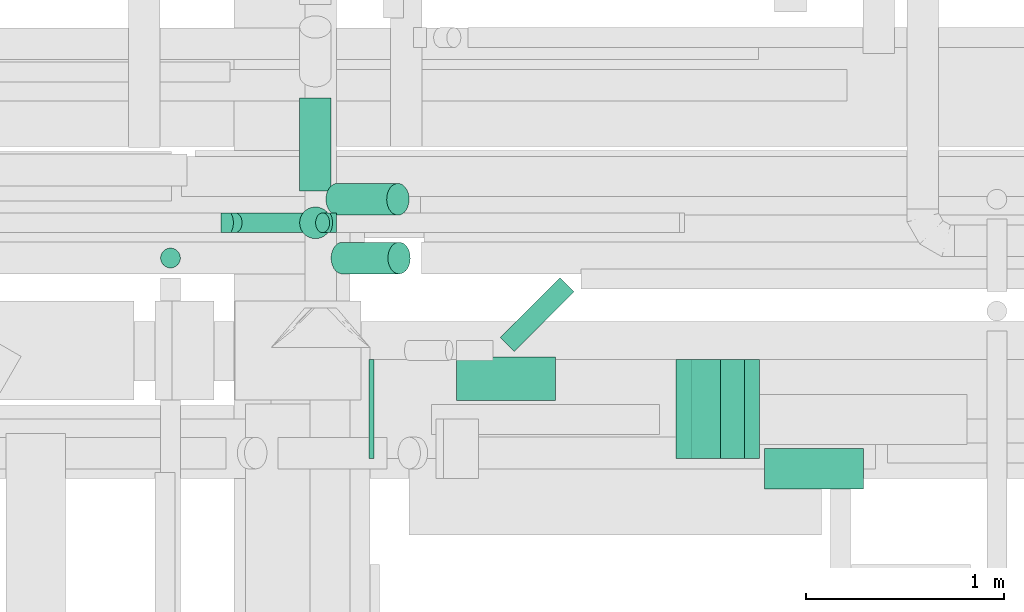
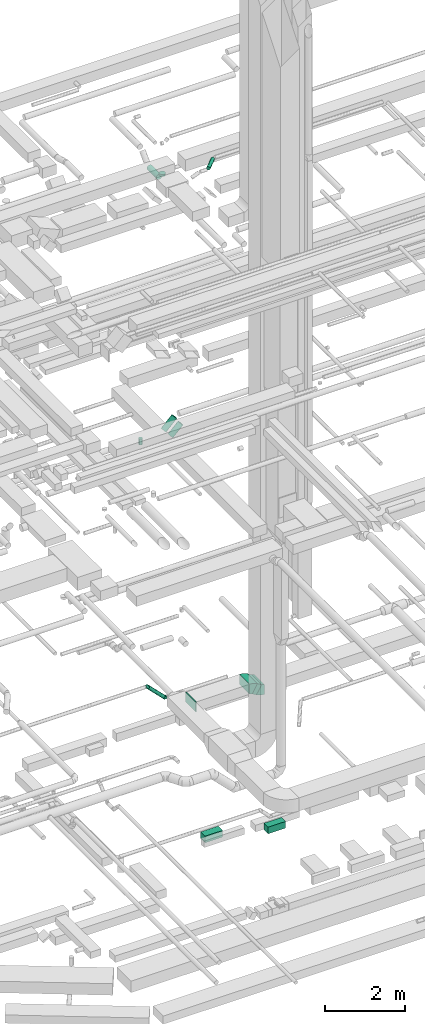
# One storey, part 135 of 337: 10 flow segments, 5 flow fittings.
"""IFC2X3 building model written with IfcOpenShell, lengths in millimetres."""

from ifc_helpers import new_model, entity, si_unit, converted_unit, derived_unit, direction, frame, frame_2d, origin, origin_2d_with_axis, place, context, subcontext, project, spatial, polyline, circle_curve, parameter, trimmed, segment, composite_curve, rectangle, circle, outline, extrude, faceted_brep, source, transform, mapped, material, type_object, type_shapes, element, save


model = new_model("IFC2X3")

# Units and contexts
model_context = context("Model", 3, precision=0.01, world=origin(), true_north=direction((6.12303176911189e-17, 1.0)))
body_context = subcontext(model_context, "Body", "Model", "MODEL_VIEW")
ifc_project = project(units=[si_unit("LENGTHUNIT", "METRE", prefix="MILLI"), si_unit("AREAUNIT", "SQUARE_METRE"), si_unit("VOLUMEUNIT", "CUBIC_METRE"), converted_unit("PLANEANGLEUNIT", "DEGREE", entity("IfcRatioMeasure", 0.0174532925199433), si_unit("PLANEANGLEUNIT", "RADIAN"), dimensions=[0, 0, 0, 0, 0, 0, 0]), si_unit("MASSUNIT", "GRAM", prefix="KILO"), derived_unit("MASSDENSITYUNIT", [(si_unit("MASSUNIT", "GRAM", prefix="KILO"), 1), (si_unit("LENGTHUNIT", "METRE"), -3)]), derived_unit("MOMENTOFINERTIAUNIT", [(si_unit("LENGTHUNIT", "METRE"), 4)]), si_unit("TIMEUNIT", "SECOND"), si_unit("FREQUENCYUNIT", "HERTZ"), si_unit("THERMODYNAMICTEMPERATUREUNIT", "DEGREE_CELSIUS"), derived_unit("THERMALTRANSMITTANCEUNIT", [(si_unit("MASSUNIT", "GRAM", prefix="KILO"), 1), (si_unit("THERMODYNAMICTEMPERATUREUNIT", "KELVIN"), -1), (si_unit("TIMEUNIT", "SECOND"), -3)]), derived_unit("VOLUMETRICFLOWRATEUNIT", [(si_unit("LENGTHUNIT", "METRE"), 3), (si_unit("TIMEUNIT", "SECOND"), -1)]), derived_unit("MASSFLOWRATEUNIT", [(si_unit("MASSUNIT", "GRAM", prefix="KILO"), 1), (si_unit("TIMEUNIT", "SECOND"), -1)]), derived_unit("ROTATIONALFREQUENCYUNIT", [(si_unit("TIMEUNIT", "SECOND"), -1)]), si_unit("ELECTRICCURRENTUNIT", "AMPERE"), si_unit("ELECTRICVOLTAGEUNIT", "VOLT"), si_unit("POWERUNIT", "WATT"), si_unit("FORCEUNIT", "NEWTON", prefix="KILO"), si_unit("ILLUMINANCEUNIT", "LUX"), si_unit("LUMINOUSFLUXUNIT", "LUMEN"), si_unit("LUMINOUSINTENSITYUNIT", "CANDELA"), derived_unit("USERDEFINED", [(si_unit("MASSUNIT", "GRAM", prefix="KILO"), -1), (si_unit("LENGTHUNIT", "METRE"), -2), (si_unit("TIMEUNIT", "SECOND"), 3), (si_unit("LUMINOUSFLUXUNIT", "LUMEN"), 1)]), derived_unit("LINEARVELOCITYUNIT", [(si_unit("LENGTHUNIT", "METRE"), 1), (si_unit("TIMEUNIT", "SECOND"), -1)]), si_unit("PRESSUREUNIT", "PASCAL"), derived_unit("USERDEFINED", [(si_unit("LENGTHUNIT", "METRE"), -2), (si_unit("MASSUNIT", "GRAM", prefix="KILO"), 1), (si_unit("TIMEUNIT", "SECOND"), -2)]), derived_unit("LINEARFORCEUNIT", [(si_unit("MASSUNIT", "GRAM", prefix="KILO"), 1), (si_unit("LENGTHUNIT", "METRE"), 1), (si_unit("TIMEUNIT", "SECOND"), -2), (si_unit("LENGTHUNIT", "METRE"), -1)]), derived_unit("PLANARFORCEUNIT", [(si_unit("MASSUNIT", "GRAM", prefix="KILO"), 1), (si_unit("LENGTHUNIT", "METRE"), 1), (si_unit("TIMEUNIT", "SECOND"), -2), (si_unit("LENGTHUNIT", "METRE"), -2)])], contexts=[model_context])

# Site, building, storey
site_placement = place(None, origin())
site = spatial("IfcSite", under=ifc_project, at=site_placement, CompositionType="ELEMENT")
building_placement = place(site_placement, origin())
building = spatial("IfcBuilding", under=site, at=building_placement, CompositionType="ELEMENT")
storey_placement = place(building_placement, origin())
storey = spatial("IfcBuildingStorey", under=building, at=storey_placement, CompositionType="ELEMENT", Elevation=0.0)

# Flow segments
duct_segment_type_1 = type_object("IfcDuctSegmentType", PredefinedType="NOTDEFINED")
flow_segment_1_placement = place(storey_placement, frame((24000.25, 14418.99, -1000.0)))
element("IfcFlowSegment", 1, at=flow_segment_1_placement, inside=storey, type_object=duct_segment_type_1, context=body_context, shape_type="SweptSolid", body=[
    extrude(rectangle(XDim=220.0, YDim=499.999999999999, at=origin_2d_with_axis()), frame((250.0, 110.0, 0.0), z_axis=(0.0, 0.0, 1.0), x_axis=(0.0, 1.0, 0.0)), (0.0, 0.0, 1.0), 200.0),
])
flow_segment_2_placement = place(storey_placement, frame((25553.23, 13973.99, -1000.0)))
element("IfcFlowSegment", 2, at=flow_segment_2_placement, inside=storey, type_object=duct_segment_type_1, context=body_context, shape_type="SweptSolid", body=[
    extrude(rectangle(XDim=204.999986748984, YDim=499.999999999999, at=origin_2d_with_axis()), frame((250.0, 102.5, 0.0), z_axis=(0.0, 0.0, 1.0), x_axis=(0.0, -1.0, 0.0)), (0.0, 0.0, 1.0), 200.0),
])
flow_segment_3_placement = place(storey_placement, frame((25183.09, 14126.58, 3210.29)))
element("IfcFlowSegment", 3, at=flow_segment_3_placement, inside=storey, type_object=duct_segment_type_1, context=body_context, shape_type="SweptSolid", body=[
    extrude(rectangle(XDim=300.0, YDim=139.230496196752, at=frame_2d((0.0, 0.0), x_axis=(0.0, 1.0))), frame((135.29, 0.0, 164.71), z_axis=(0.0, 1.0, 0.0), x_axis=(-0.866025410712616, 0.0, 0.499999988000045)), (0.0, 0.0, 1.0), 499.999999999999),
])
duct_segment_type_2 = type_object("IfcDuctSegmentType", PredefinedType="NOTDEFINED")
flow_segment_4_placement = place(storey_placement, frame((23366.75, 15056.69, 11058.7)))
element("IfcFlowSegment", 4, at=flow_segment_4_placement, inside=storey, type_object=duct_segment_type_2, context=body_context, shape_type="SweptSolid", body=[
    extrude(circle(Radius=80.0, at=origin_2d_with_axis()), frame((58.16, 81.6, 58.16), z_axis=(0.707106781186548, 0.0, 0.707106781186548), x_axis=(0.0, -1.0, 0.0)), (0.0, 0.0, 1.0), 404.852813742363),
])
flow_segment_5_placement = place(storey_placement, frame((23340.75, 15353.25, 11058.7)))
element("IfcFlowSegment", 5, at=flow_segment_5_placement, inside=storey, type_object=duct_segment_type_2, context=body_context, shape_type="SweptSolid", body=[
    extrude(circle(Radius=80.0, at=origin_2d_with_axis()), frame((58.16, 81.6, 58.16), z_axis=(0.707106781186548, 0.0, 0.707106781186548), x_axis=(0.0, -1.0, 0.0)), (0.0, 0.0, 1.0), 433.137084989856),
])
flow_segment_6_placement = place(storey_placement, frame((22847.03, 15264.53, 3092.34)))
element("IfcFlowSegment", 6, at=flow_segment_6_placement, inside=storey, type_object=duct_segment_type_2, context=body_context, shape_type="SweptSolid", body=[
    extrude(circle(Radius=50.0, at=origin_2d_with_axis()), frame((36.95, 51.6, 478.37), z_axis=(0.707106781186545, 0.0, -0.70710678118655), x_axis=(0.0, 1.0, 0.0)), (0.0, 0.0, 1.0), 624.264068711905),
])
flow_segment_7_placement = place(storey_placement, frame((22506.56, 15086.69, 11170.0)))
element("IfcFlowSegment", 7, at=flow_segment_7_placement, inside=storey, type_object=duct_segment_type_2, context=body_context, shape_type="SweptSolid", body=[
    extrude(circle(Radius=50.0, at=origin_2d_with_axis()), frame((51.6, 51.6, 0.0), z_axis=(0.0, 0.0, 1.0), x_axis=(-1.0, 0.0, 0.0)), (0.0, 0.0, 1.0), 179.999999999998),
])
flow_segment_8_placement = place(storey_placement, frame((24219.86, 14665.24, 19148.91)))
element("IfcFlowSegment", 8, at=flow_segment_8_placement, inside=storey, type_object=duct_segment_type_2, context=body_context, shape_type="SweptSolid", body=[
    extrude(circle(Radius=50.0, at=origin_2d_with_axis()), frame((36.95, 36.95, 51.6), z_axis=(0.707106781186558, 0.707106781186537, 0.0), x_axis=(-0.707106781186537, 0.707106781186558, 0.0)), (0.0, 0.0, 1.0), 426.274169979706),
])
flow_segment_9_placement = place(storey_placement, frame((23207.77, 15476.15, 18728.99)))
element("IfcFlowSegment", 9, at=flow_segment_9_placement, inside=storey, type_object=duct_segment_type_2, context=body_context, shape_type="SweptSolid", body=[
    extrude(circle(Radius=80.0, at=origin_2d_with_axis()), frame((81.6, 0.0, 81.6), z_axis=(0.0, 1.0, 0.0), x_axis=(-1.0, 0.0, 0.0)), (0.0, 0.0, 1.0), 468.725830020335),
])
flow_segment_10_placement = place(storey_placement, frame((23207.77, 15234.56, 18970.59)))
element("IfcFlowSegment", 10, at=flow_segment_10_placement, inside=storey, type_object=duct_segment_type_2, context=body_context, shape_type="SweptSolid", body=[
    extrude(circle(Radius=80.0, at=origin_2d_with_axis()), frame((81.6, 81.6, 0.0), z_axis=(0.0, 0.0, 1.0), x_axis=(-1.0, 0.0, 0.0)), (0.0, 0.0, 1.0), 59.4112549694471),
])

# Flow fittings
ifc_material = material()
duct_fitting_type_1 = type_object("IfcDuctFittingType", PredefinedType="NOTDEFINED", material=ifc_material)
shared_shape_1 = source(origin(), body_context, "Body", "SweptSolid", [
    extrude(rectangle(XDim=26.0960000000224, YDim=500.0, at=origin_2d_with_axis()), frame((6.95, 0.0, -150.0)), (0.0, 0.0, 1.0), 300.0),
])
type_shapes(duct_fitting_type_1, [shared_shape_1])
flow_fitting_placement = place(storey_placement, frame((23565.55, 14376.58, 3450.0), z_axis=(0.0, 0.0, -1.0), x_axis=(1.0, 0.0, 0.0)))
element("IfcFlowFitting", 11, at=flow_fitting_placement, inside=storey, type_object=duct_fitting_type_1, material=ifc_material, context=body_context, shape_type="MappedRepresentation", body=[
    mapped(shared_shape_1, transform((0.0, 0.0, 0.0), scale=1.0)),
])
duct_fitting_type_2 = type_object("IfcDuctFittingType", PredefinedType="NOTDEFINED", material=ifc_material)
shared_shape_2 = source(origin(), body_context, "Body", "Brep", [
    faceted_brep([(-41.42, 0.0, -50.0), (-41.42, -12.94, -48.3), (-41.42, -25.0, -43.3), (-41.42, -35.36, -35.36), (-41.42, -43.3, -25.0), (-41.42, -48.3, -12.94), (-41.42, -50.0, 0.0), (-41.42, -48.3, 12.94), (-41.42, -43.3, 25.0), (-41.42, -35.36, 35.36), (-41.42, -25.0, 43.3), (-41.42, -12.94, 48.3), (-41.42, 0.0, 50.0), (-41.42, 12.94, 48.3), (-41.42, 25.0, 43.3), (-41.42, 35.36, 35.36), (-41.42, 43.3, 25.0), (-41.42, 48.3, 12.94), (-41.42, 50.0, 0.0), (-41.42, 48.3, -12.94), (-41.42, 43.3, -25.0), (-41.42, 35.36, -35.36), (-41.42, 25.0, -43.3), (-41.42, 12.94, -48.3), (-5.36, 12.94, 48.3), (-10.36, 25.0, 43.3), (0.0, 0.0, 50.0), (-14.64, 35.36, 35.36), (-20.0, 48.3, 12.94), (-20.71, 50.0, 0.0), (-17.94, 43.3, 25.0), (-17.94, 43.3, -25.0), (-14.64, 35.36, -35.36), (-20.0, 48.3, -12.94), (-5.36, 12.94, -48.3), (0.0, 0.0, -50.0), (-10.36, 25.0, -43.3), (5.36, -12.94, -48.3), (10.36, -25.0, -43.3), (14.64, -35.36, -35.36), (17.94, -43.3, -25.0), (20.0, -48.3, -12.94), (20.71, -50.0, 0.0), (20.0, -48.3, 12.94), (17.94, -43.3, 25.0), (14.64, -35.36, 35.36), (10.36, -25.0, 43.3), (5.36, -12.94, 48.3), (29.29, 29.29, 50.0), (20.14, 38.44, 48.3), (11.61, 46.97, 43.3), (4.29, 54.29, 35.36), (-1.33, 59.91, 25.0), (-4.86, 63.44, 12.94), (-6.07, 64.64, 0.0), (-4.86, 63.44, -12.94), (-1.33, 59.91, -25.0), (4.29, 54.29, -35.36), (11.61, 46.97, -43.3), (20.14, 38.44, -48.3), (29.29, 29.29, -50.0), (38.44, 20.14, -48.3), (46.97, 11.61, -43.3), (54.29, 4.29, -35.36), (59.91, -1.33, -25.0), (63.44, -4.86, -12.94), (64.64, -6.07, 0.0), (63.44, -4.86, 12.94), (59.91, -1.33, 25.0), (54.29, 4.29, 35.36), (46.97, 11.61, 43.3), (38.44, 20.14, 48.3)], [[[0, 1, 2, 3, 4, 5, 6, 7, 8, 9, 10, 11, 12, 13, 14, 15, 16, 17, 18, 19, 20, 21, 22, 23]], [[24, 25, 14, 13]], [[26, 24, 13, 12]], [[14, 25, 27, 15]], [[28, 29, 18, 17]], [[30, 28, 17, 16]], [[16, 15, 27, 30]], [[20, 31, 32, 21]], [[33, 31, 20, 19]], [[18, 29, 33, 19]], [[34, 35, 0, 23]], [[36, 34, 23, 22]], [[32, 36, 22, 21]], [[1, 0, 35, 37]], [[2, 1, 37, 38]], [[38, 39, 3, 2]], [[5, 4, 40, 41]], [[6, 5, 41, 42]], [[39, 40, 4, 3]], [[6, 42, 43, 7]], [[7, 43, 44, 8]], [[8, 44, 45, 9]], [[9, 45, 46, 10]], [[10, 46, 47, 11]], [[26, 12, 11, 47]], [[24, 26, 48, 49]], [[25, 24, 49, 50]], [[27, 25, 50, 51]], [[28, 30, 52, 53]], [[29, 28, 53, 54]], [[27, 51, 52, 30]], [[29, 54, 55, 33]], [[33, 55, 56, 31]], [[31, 56, 57, 32]], [[36, 58, 59, 34]], [[34, 59, 60, 35]], [[36, 32, 57, 58]], [[61, 62, 38, 37]], [[60, 61, 37, 35]], [[63, 39, 38, 62]], [[40, 64, 65, 41]], [[41, 65, 66, 42]], [[64, 40, 39, 63]], [[43, 42, 66, 67]], [[44, 43, 67, 68]], [[68, 69, 45, 44]], [[47, 46, 70, 71]], [[26, 47, 71, 48]], [[69, 70, 46, 45]], [[59, 58, 57, 56, 55, 54, 53, 52, 51, 50, 49, 48, 71, 70, 69, 68, 67, 66, 65, 64, 63, 62, 61, 60]]]),
])
type_shapes(duct_fitting_type_2, [shared_shape_2])
for number, where, z_axis, x_axis in (
    (12, (23354.69, 15316.13, 3100.0), (0.0, 1.0, 0.0), (-1.0, 0.0, 0.0)),
    (13, (22854.69, 15316.13, 3600.0), (0.0, 1.0, 0.0), (1.0, 0.0, 0.0)),
):
    element("IfcFlowFitting", number, at=place(storey_placement, frame(where, z_axis=z_axis, x_axis=x_axis)), inside=storey, type_object=duct_fitting_type_2, material=ifc_material, context=body_context, shape_type="MappedRepresentation", body=[
        mapped(shared_shape_2, transform((0.0, 0.0, 0.0), scale=1.0)),
    ])
duct_fitting_type_3 = type_object("IfcDuctFittingType", PredefinedType="NOTDEFINED", material=ifc_material)
shared_shape_3 = source(origin(), body_context, "Body", "SweptSolid", [
    extrude(outline(composite_curve([segment(polyline([(-170.1, -75.0), (129.9, -75.0)]), True, "CONTINUOUS"), segment(trimmed(circle_curve(frame_2d((279.9, -75.0), x_axis=(-0.86602541071262, 0.499999988000035)), 150.0), [parameter(0.0)], [parameter(29.9999992060887)], True, "PARAMETER"), False, "CONTINUOUS"), segment(polyline([(150.0, 0.0), (-109.81, 150.0)]), True, "CONTINUOUS"), segment(trimmed(circle_curve(frame_2d((279.9, -75.0), x_axis=(-0.86602541071262, 0.499999988000035)), 450.0), [parameter(0.0)], [parameter(29.9999992060887)], True, "PARAMETER"), True, "CONTINUOUS")], self_intersect=False)), frame((-5.38, 20.1, -250.0), z_axis=(0.0, 0.0, 1.0), x_axis=(-0.499999988000034, 0.866025410712622, 0.0)), (0.0, 0.0, 1.0), 500.0),
])
type_shapes(duct_fitting_type_3, [shared_shape_3])
for number, where, z_axis, x_axis in (
    (14, (25448.28, 14376.58, 3300.0), (0.0, 1.0, 0.0), (-1.0, 0.0, 0.0)),
    (15, (25188.48, 14376.58, 3450.0), (0.0, -1.0, 0.0), (-0.866025410712577, 0.0, 0.499999988000113)),
):
    element("IfcFlowFitting", number, at=place(storey_placement, frame(where, z_axis=z_axis, x_axis=x_axis)), inside=storey, type_object=duct_fitting_type_3, material=ifc_material, context=body_context, shape_type="MappedRepresentation", body=[
        mapped(shared_shape_3, transform((0.0, 0.0, 0.0), scale=1.0)),
    ])

save(model, "model.ifc")
